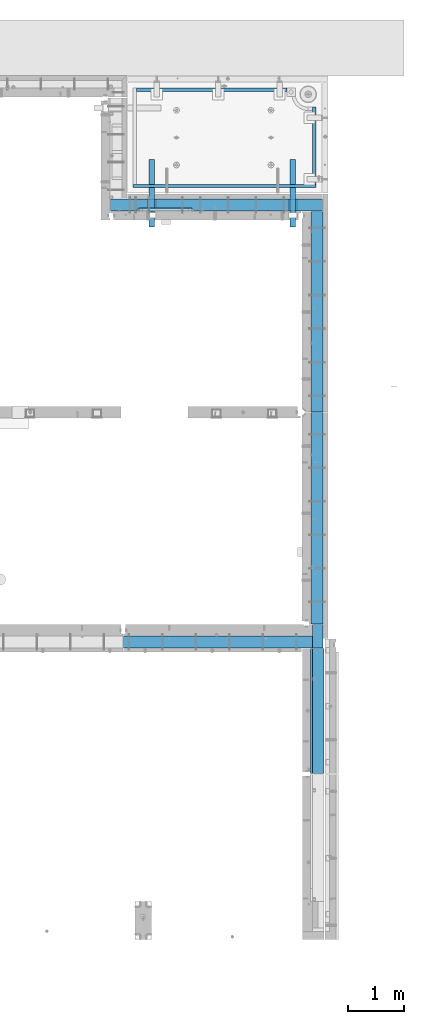
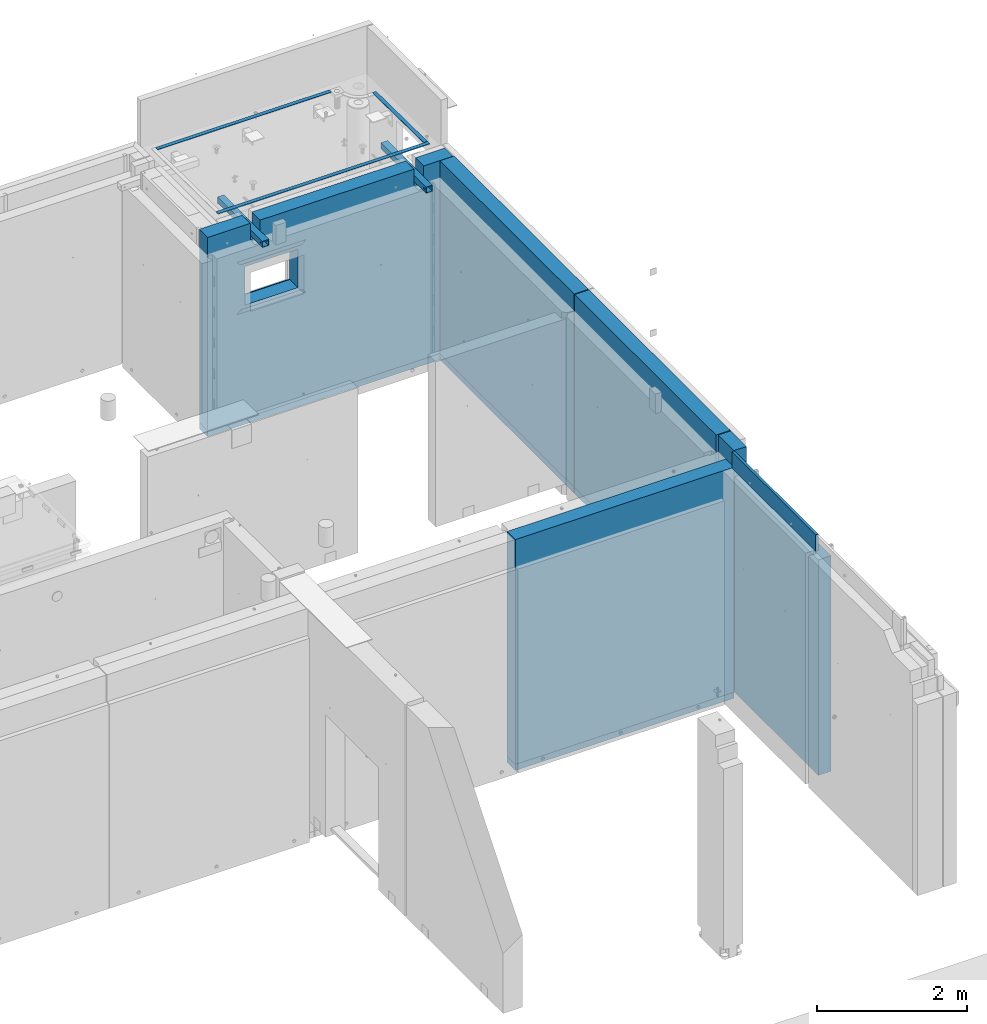
# One storey, part 83 of 264: 18 beams, 13 elements without a shape of their own.
"""IFC2X3 building model written with IfcOpenShell, lengths in millimetres."""

from ifc_helpers import new_model, si_unit, frame, origin_with_axes, place, context, subcontext, project, spatial, faceted_brep, material, type_object, element, aggregate, save


model = new_model("IFC2X3")

# Units and contexts
model_context = context("Model", 3, precision=1e-05, world=origin_with_axes())
body_context = subcontext(model_context, "Body", "Model", "MODEL_VIEW")
ifc_project = project(units=[si_unit("LENGTHUNIT", "METRE", prefix="MILLI"), si_unit("AREAUNIT", "SQUARE_METRE"), si_unit("VOLUMEUNIT", "CUBIC_METRE"), si_unit("MASSUNIT", "GRAM", prefix="KILO"), si_unit("TIMEUNIT", "SECOND"), si_unit("PLANEANGLEUNIT", "RADIAN"), si_unit("SOLIDANGLEUNIT", "STERADIAN"), si_unit("THERMODYNAMICTEMPERATUREUNIT", "DEGREE_CELSIUS"), si_unit("LUMINOUSINTENSITYUNIT", "LUMEN")], contexts=[model_context])

# Site, building, storey
site_placement = place(None, origin_with_axes())
site = spatial("IfcSite", under=ifc_project, at=site_placement, CompositionType="ELEMENT")
building_placement = place(site_placement, origin_with_axes())
building = spatial("IfcBuilding", under=site, at=building_placement, CompositionType="ELEMENT")
storey_placement = place(building_placement, origin_with_axes())
storey = spatial("IfcBuildingStorey", under=building, at=storey_placement, Name="K", CompositionType="ELEMENT", Elevation=0.0)

# Assemblies, beams
assembly_1_placement = place(storey_placement, origin_with_axes())
assembly_1 = element("IfcElementAssembly", 1, at=assembly_1_placement, inside=storey, AssemblyPlace="NOTDEFINED", PredefinedType="REINFORCEMENT_UNIT")
assembly_2_placement = place(assembly_1_placement, origin_with_axes())
assembly_2 = element("IfcElementAssembly", 2, at=assembly_2_placement, AssemblyPlace="NOTDEFINED", PredefinedType="NOTDEFINED")
ifc_material_1 = material(Name="Undefined/350")
beam_type_1 = type_object("IfcBeamType", Name="100X100X5", PredefinedType="NOTDEFINED")
beam_1_placement = place(assembly_2_placement, frame((34735.0001432011, 21500.0034426031, 81555.0), z_axis=(0.0, 0.0, 1.0), x_axis=(-2.2242999997242e-05, -0.999999999752625, 0.0)))
beam_1 = element("IfcBeam", 3, at=beam_1_placement, type_object=beam_type_1, material=ifc_material_1, ObjectType="100X100X5", context=body_context, shape_type="Brep", body=[
    faceted_brep([(1143.75108023171, 44.9999999999982, -10.8253175473074), (1143.75107855316, 50.0255964196231, -10.8253175473074), (1139.17576100585, 50.0255948914664, -6.25), (1139.1757626844, 44.9999999999982, -6.25), (1150.00108023171, 44.9999999999982, -12.5), (1150.00107855316, 50.0255985071226, -12.5), (1156.2510802317, 44.9999999999982, -10.8253175473074), (1156.25107855315, 50.0256005946221, -10.8253175473074), (1160.82639777901, 44.9999999999982, -6.25), (1160.82639610046, 50.0256021227788, -6.25), (1162.50108023171, 44.9999999999982, 0.0), (1162.50107855316, 50.0256026821226, 0.0), (1160.82639777901, 44.9999999999982, 6.25), (1160.82639610046, 50.0256021227788, 6.25), (1156.2510802317, 44.9999999999982, 10.8253175473074), (1156.25107855315, 50.0256005946221, 10.8253175473074), (1150.00108023171, 44.9999999999982, 12.5), (1150.00107855316, 50.0255985071226, 12.5), (1143.75108023171, 44.9999999999982, 10.8253175473074), (1143.75107855316, 50.0255964196231, 10.8253175473074), (1139.1757626844, 44.9999999999982, 6.25), (1139.17576100585, 50.0255948914664, 6.25), (1137.5010802317, 44.9999999999982, 0.0), (1137.50107855316, 50.0255943321226, 0.0), (1143.75111195316, -49.9744035792783, -10.8253175473074), (1143.75111029171, -44.9999999999991, -10.8253175473074), (1139.1757927444, -44.9999999999991, -6.25), (1139.17579440585, -49.9744051074349, -6.25), (1150.00111195316, -49.9744014917787, -12.5), (1150.00111029171, -44.9999999999991, -12.5), (1156.25111195316, -49.9743994042774, -10.8253175473074), (1156.25111029171, -44.9999999999991, -10.8253175473074), (1160.82642950046, -49.9743978761207, -6.25), (1160.82642783901, -44.9999999999991, -6.25), (1162.50111195316, -49.9743973167779, 0.0), (1162.50111029171, -44.9999999999991, 0.0), (1160.82642950046, -49.9743978761207, 6.25), (1160.82642783901, -44.9999999999991, 6.25), (1156.25111195316, -49.9743994042774, 10.8253175473074), (1156.25111029171, -44.9999999999991, 10.8253175473074), (1150.00111195316, -49.9744014917787, 12.5), (1150.00111029171, -44.9999999999991, 12.5), (1143.75111195316, -49.9744035792783, 10.8253175473074), (1143.75111029171, -44.9999999999991, 10.8253175473074), (1139.17579440585, -49.9744051074349, 6.25), (1139.1757927444, -44.9999999999991, 6.25), (1137.50111195316, -49.9744056667778, 0.0), (1137.50111029171, -44.9999999999991, 0.0), (1.81898940354586e-12, -50.0000000000009, -50.0), (1.81898940354586e-12, 49.9999999999991, -50.0), (1200.00449189278, 49.9999999999982, -50.0), (1200.00449189278, -50.0000000000009, -50.0), (1.81898940354586e-12, 49.9999999999991, 50.0), (1.81898940354586e-12, -50.0000000000009, 50.0), (1200.00449189278, -50.0000000000009, 50.0), (1200.00449189278, 49.9999999999982, 50.0), (0.0, 44.9999999999991, 45.0), (1.81898940354586e-12, -45.0000000000009, 45.0), (1.81898940354586e-12, -45.0000000000009, -45.0), (0.0, 44.9999999999991, -45.0), (1200.00449189278, 44.9999999999982, -45.0), (1200.00449189278, 44.9999999999982, 45.0), (1200.00449189278, -45.0000000000009, 45.0), (1200.00449189278, -45.0000000000009, -45.0)], [[[0, 1, 2, 3]], [[4, 5, 1, 0]], [[6, 7, 5, 4]], [[8, 9, 7, 6]], [[10, 11, 9, 8]], [[12, 13, 11, 10]], [[14, 15, 13, 12]], [[16, 17, 15, 14]], [[18, 19, 17, 16]], [[20, 21, 19, 18]], [[22, 23, 21, 20]], [[3, 2, 23, 22]], [[24, 25, 26, 27]], [[28, 29, 25, 24]], [[30, 31, 29, 28]], [[32, 33, 31, 30]], [[34, 35, 33, 32]], [[36, 37, 35, 34]], [[38, 39, 37, 36]], [[40, 41, 39, 38]], [[42, 43, 41, 40]], [[44, 45, 43, 42]], [[46, 47, 45, 44]], [[27, 26, 47, 46]], [[48, 49, 50, 51]], [[52, 53, 54, 55]], [[49, 52, 55, 50], [15, 17, 19, 21, 23, 2, 1, 5, 7, 9, 11, 13]], [[48, 53, 52, 49], [56, 57, 58, 59]], [[56, 59, 60, 61], [6, 4, 0, 3, 22, 20, 18, 16, 14, 12, 10, 8]], [[57, 56, 61, 62]], [[58, 57, 62, 63], [39, 41, 43, 45, 47, 26, 25, 29, 31, 33, 35, 37]], [[59, 58, 63, 60]], [[54, 51, 50, 55], [62, 61, 60, 63]], [[53, 48, 51, 54], [30, 28, 24, 27, 46, 44, 42, 40, 38, 36, 34, 32]]]),
])
aggregate(assembly_2, [beam_1])
assembly_3_placement = place(assembly_1_placement, origin_with_axes())
assembly_3 = element("IfcElementAssembly", 4, at=assembly_3_placement, AssemblyPlace="NOTDEFINED", PredefinedType="NOTDEFINED")
beam_2_placement = place(assembly_3_placement, frame((32210.0001432011, 21500.0034426031, 81555.0), z_axis=(0.0, 0.0, 1.0), x_axis=(-2.2242999997242e-05, -0.999999999752625, 0.0)))
beam_2 = element("IfcBeam", 5, at=beam_2_placement, type_object=beam_type_1, material=ifc_material_1, ObjectType="100X100X5", context=body_context, shape_type="Brep", body=[
    faceted_brep([(1143.75108023171, 44.9999999999982, -10.8253175473074), (1143.75107855316, 50.0255964196231, -10.8253175473074), (1139.17576100585, 50.0255948914664, -6.25), (1139.1757626844, 44.9999999999982, -6.25), (1150.00108023171, 44.9999999999982, -12.5), (1150.00107855316, 50.0255985071226, -12.5), (1156.2510802317, 44.9999999999982, -10.8253175473074), (1156.25107855315, 50.0256005946221, -10.8253175473074), (1160.82639777901, 44.9999999999982, -6.25), (1160.82639610046, 50.0256021227788, -6.25), (1162.50108023171, 44.9999999999982, 0.0), (1162.50107855316, 50.0256026821226, 0.0), (1160.82639777901, 44.9999999999982, 6.25), (1160.82639610046, 50.0256021227788, 6.25), (1156.2510802317, 44.9999999999982, 10.8253175473074), (1156.25107855315, 50.0256005946221, 10.8253175473074), (1150.00108023171, 44.9999999999982, 12.5), (1150.00107855316, 50.0255985071226, 12.5), (1143.75108023171, 44.9999999999982, 10.8253175473074), (1143.75107855316, 50.0255964196231, 10.8253175473074), (1139.1757626844, 44.9999999999982, 6.25), (1139.17576100585, 50.0255948914664, 6.25), (1137.5010802317, 44.9999999999982, 0.0), (1137.50107855316, 50.0255943321226, 0.0), (1143.75111195316, -49.9744035792783, -10.8253175473074), (1143.75111029171, -44.9999999999991, -10.8253175473074), (1139.1757927444, -44.9999999999991, -6.25), (1139.17579440585, -49.9744051074349, -6.25), (1150.00111195316, -49.9744014917787, -12.5), (1150.00111029171, -44.9999999999991, -12.5), (1156.25111195316, -49.9743994042774, -10.8253175473074), (1156.25111029171, -44.9999999999991, -10.8253175473074), (1160.82642950046, -49.9743978761207, -6.25), (1160.82642783901, -44.9999999999991, -6.25), (1162.50111195316, -49.9743973167779, 0.0), (1162.50111029171, -44.9999999999991, 0.0), (1160.82642950046, -49.9743978761207, 6.25), (1160.82642783901, -44.9999999999991, 6.25), (1156.25111195316, -49.9743994042774, 10.8253175473074), (1156.25111029171, -44.9999999999991, 10.8253175473074), (1150.00111195316, -49.9744014917787, 12.5), (1150.00111029171, -44.9999999999991, 12.5), (1143.75111195316, -49.9744035792783, 10.8253175473074), (1143.75111029171, -44.9999999999991, 10.8253175473074), (1139.17579440585, -49.9744051074349, 6.25), (1139.1757927444, -44.9999999999991, 6.25), (1137.50111195316, -49.9744056667778, 0.0), (1137.50111029171, -44.9999999999991, 0.0), (1.81898940354586e-12, -50.0000000000009, -50.0), (1.81898940354586e-12, 49.9999999999991, -50.0), (1200.00449189278, 49.9999999999982, -50.0), (1200.00449189278, -50.0000000000009, -50.0), (1.81898940354586e-12, 49.9999999999991, 50.0), (1.81898940354586e-12, -50.0000000000009, 50.0), (1200.00449189278, -50.0000000000009, 50.0), (1200.00449189278, 49.9999999999982, 50.0), (0.0, 44.9999999999991, 45.0), (1.81898940354586e-12, -45.0000000000009, 45.0), (1.81898940354586e-12, -45.0000000000009, -45.0), (0.0, 44.9999999999991, -45.0), (1200.00449189278, 44.9999999999982, -45.0), (1200.00449189278, 44.9999999999982, 45.0), (1200.00449189278, -45.0000000000009, 45.0), (1200.00449189278, -45.0000000000009, -45.0)], [[[0, 1, 2, 3]], [[4, 5, 1, 0]], [[6, 7, 5, 4]], [[8, 9, 7, 6]], [[10, 11, 9, 8]], [[12, 13, 11, 10]], [[14, 15, 13, 12]], [[16, 17, 15, 14]], [[18, 19, 17, 16]], [[20, 21, 19, 18]], [[22, 23, 21, 20]], [[3, 2, 23, 22]], [[24, 25, 26, 27]], [[28, 29, 25, 24]], [[30, 31, 29, 28]], [[32, 33, 31, 30]], [[34, 35, 33, 32]], [[36, 37, 35, 34]], [[38, 39, 37, 36]], [[40, 41, 39, 38]], [[42, 43, 41, 40]], [[44, 45, 43, 42]], [[46, 47, 45, 44]], [[27, 26, 47, 46]], [[48, 49, 50, 51]], [[52, 53, 54, 55]], [[49, 52, 55, 50], [15, 17, 19, 21, 23, 2, 1, 5, 7, 9, 11, 13]], [[48, 53, 52, 49], [56, 57, 58, 59]], [[56, 59, 60, 61], [6, 4, 0, 3, 22, 20, 18, 16, 14, 12, 10, 8]], [[57, 56, 61, 62]], [[58, 57, 62, 63], [39, 41, 43, 45, 47, 26, 25, 29, 31, 33, 35, 37]], [[59, 58, 63, 60]], [[54, 51, 50, 55], [62, 61, 60, 63]], [[53, 48, 51, 54], [30, 28, 24, 27, 46, 44, 42, 40, 38, 36, 34, 32]]]),
])
aggregate(assembly_3, [beam_2])
ifc_material_2 = material(Name="CONCRETE/Concrete_Undefined")
beam_type_2 = type_object("IfcBeamType", PredefinedType="NOTDEFINED")
beam_3_placement = place(assembly_1_placement, frame((31939.9962088559, 22755.0460044387, 81704.8214945609), z_axis=(-6.06120000110142e-05, 1.00000033869885e-09, 0.999999998163093), x_axis=(0.999999998046552, -1.52670000006885e-05, 6.06120000021532e-05)))
beam_3 = element("IfcBeam", 6, at=beam_3_placement, type_object=beam_type_2, material=ifc_material_2, context=body_context, shape_type="Brep", body=[
    faceted_brep([(2.5465851649642e-11, 29.9999999999982, -4.99999999998545), (-2.91038304567337e-11, 29.9999999999982, 5.0), (2689.99575395095, 29.9999999999964, 5.0), (2689.99575395095, 30.0000000000036, -4.99999999998545), (-2.5465851649642e-11, -30.0000000000018, 5.0), (2689.99575395095, -30.0000000000036, 5.00000000001455), (2.72848410531878e-11, -30.0000000000018, -4.99999999998545), (2689.99575395095, -29.9999999999964, -4.99999999998545)], [[[0, 1, 2, 3]], [[1, 4, 5, 2]], [[4, 6, 7, 5]], [[6, 0, 3, 7]], [[5, 7, 3, 2]], [[6, 4, 1, 0]]]),
])
beam_4_placement = place(assembly_1_placement, frame((35120.0586113047, 21059.9283388168, 81725.6638339053), z_axis=(-5.46000002942176e-07, 0.0130421150000144, 0.999914948001093), x_axis=(-4.18520000064741e-05, 0.999914947125351, -0.0130421150016393)))
beam_4 = element("IfcBeam", 7, at=beam_4_placement, type_object=beam_type_2, material=ifc_material_2, context=body_context, shape_type="Brep", body=[
    faceted_brep([(2.5465851649642e-11, 29.9999999999982, -4.99999999998545), (-2.91038304567337e-11, 29.9999999999982, 5.0), (1380.14316164461, 30.0, 5.00000000001455), (1380.1431616447, 29.9999999999927, -5.0), (-2.5465851649642e-11, -30.0000000000018, 5.0), (1380.14316164461, -30.0, 5.00000000001455), (2.72848410531878e-11, -30.0000000000018, -4.99999999998545), (1380.1431616447, -30.0, -5.0)], [[[0, 1, 2, 3]], [[1, 4, 5, 2]], [[4, 6, 7, 5]], [[6, 0, 3, 7]], [[5, 7, 3, 2]], [[6, 4, 1, 0]]]),
])
beam_5_placement = place(assembly_1_placement, frame((31879.9986204165, 21030.068155681, 81725.2788443041), z_axis=(-0.000117617000009658, 3.00000101585662e-09, 0.999999993083121), x_axis=(0.999999992839137, -2.20899999960382e-05, 0.000117616999982089)))
beam_5 = element("IfcBeam", 8, at=beam_5_placement, type_object=beam_type_2, material=ifc_material_2, context=body_context, shape_type="Brep", body=[
    faceted_brep([(2.5465851649642e-11, 29.9999999999982, -4.99999999998545), (-2.91038304567337e-11, 29.9999999999982, 5.0), (3270.06002088557, 30.0, 5.0), (3270.06002088557, 30.0000000000036, -5.0), (-2.5465851649642e-11, -30.0000000000018, 5.0), (3270.06002088557, -30.0, 5.0), (2.72848410531878e-11, -30.0000000000018, -4.99999999998545), (3270.06002088558, -29.9999999999964, -5.0)], [[[0, 1, 2, 3]], [[1, 4, 5, 2]], [[4, 6, 7, 5]], [[6, 0, 3, 7]], [[5, 7, 3, 2]], [[6, 4, 1, 0]]]),
])
aggregate(assembly_1, [assembly_2, assembly_3, beam_3, beam_4, beam_5])

# Assembly, beams
assembly_4_placement = place(storey_placement, origin_with_axes())
assembly_4 = element("IfcElementAssembly", 9, at=assembly_4_placement, inside=storey, AssemblyPlace="NOTDEFINED", PredefinedType="REINFORCEMENT_UNIT")
ifc_material_3 = material(Name="CONCRETE/C25/30")
beam_type_3 = type_object("IfcBeamType", PredefinedType="NOTDEFINED")
beam_6_placement = place(assembly_4_placement, frame((32995.0013718009, 20610.0, 81145.0), z_axis=(0.0, 0.0, -1.0), x_axis=(-1.0, 3.00000001838171e-08, 0.0)))
beam_6 = element("IfcBeam", 10, at=beam_6_placement, type_object=beam_type_3, material=ifc_material_3, context=body_context, shape_type="Brep", body=[
    faceted_brep([(60.0000000000073, 30.0, 30.0), (0.0, -30.0, -30.0), (60.0000000000073, -30.0, 30.0), (1010.00305175781, 30.0, 30.0), (1070.00305175781, -30.0, -30.0), (1010.00305175781, -30.0, 30.0)], [[[0, 1, 2]], [[1, 0, 3, 4]], [[2, 1, 4, 5]], [[0, 2, 5, 3]], [[4, 3, 5]]]),
])
beam_7_placement = place(assembly_4_placement, frame((31924.9983200431, 20610.0, 80350.0), z_axis=(0.0, 0.0, 1.0), x_axis=(1.0, 0.0, 0.0)))
beam_7 = element("IfcBeam", 11, at=beam_7_placement, type_object=beam_type_3, material=ifc_material_3, context=body_context, shape_type="Brep", body=[
    faceted_brep([(1070.00305175781, -30.0, -30.0), (1010.00305175781, 30.0, 30.0), (1010.00305175781, -30.0, 30.0), (60.0000000000073, 30.0, 30.0), (60.0000000000073, -30.0, 30.0), (0.0, -30.0, -30.0)], [[[0, 1, 2]], [[3, 4, 2, 1]], [[3, 5, 4]], [[4, 5, 0, 2]], [[5, 3, 1, 0]]]),
])

# Assembly, beam
assembly_5_placement = place(storey_placement, origin_with_axes())
assembly_5 = element("IfcElementAssembly", 12, at=assembly_5_placement, inside=storey, AssemblyPlace="NOTDEFINED", PredefinedType="REINFORCEMENT_UNIT")
beam_type_4 = type_object("IfcBeamType", PredefinedType="NOTDEFINED")
beam_8_placement = place(assembly_5_placement, frame((35085.0024573137, 12870.0018965848, 77750.0), z_axis=(0.0, 0.0, 1.0), x_axis=(-1.0, 3.00000001838171e-08, 0.0)))
beam_8 = element("IfcBeam", 13, at=beam_8_placement, type_object=beam_type_4, material=ifc_material_3, context=body_context, shape_type="Brep", body=[
    faceted_brep([(-3.63797880709171e-12, 109.999999999996, -50.0), (-3.63797880709171e-12, 109.999999999996, 50.0), (3375.0, 110.0, 50.0), (3375.0, 110.0, -50.0), (-3.63797880709171e-12, -110.0, 50.0), (3375.0, -110.0, 50.0), (-3.63797880709171e-12, -110.0, -50.0), (3375.0, -110.0, -50.0)], [[[0, 1, 2, 3]], [[1, 4, 5, 2]], [[4, 6, 7, 5]], [[6, 0, 3, 7]], [[5, 7, 3, 2]], [[6, 4, 1, 0]]]),
])

assembly_6_placement = place(storey_placement, origin_with_axes())
assembly_6 = element("IfcElementAssembly", 14, at=assembly_6_placement, inside=storey, AssemblyPlace="NOTDEFINED", PredefinedType="REINFORCEMENT_UNIT")
beam_9_placement = place(assembly_6_placement, frame((35170.0000031915, 16975.0004177926, 78540.0), z_axis=(0.0, 0.0, 1.0), x_axis=(0.0, -1.0, 0.0)))
beam_9 = element("IfcBeam", 15, at=beam_9_placement, type_object=beam_type_4, material=ifc_material_3, context=body_context, shape_type="Brep", body=[
    faceted_brep([(0.000245261930103879, 110.000000000007, -50.0), (0.000245261930103879, 110.000000000007, 50.0), (3779.99844964643, 110.000000000007, 50.0), (3779.99844964643, 110.000000000007, -50.0), (0.00010204192949459, -110.0, 50.0), (3779.99844964643, -110.0, 50.0), (0.00010204192949459, -110.0, -50.0), (3779.99844964643, -110.0, -50.0)], [[[0, 1, 2, 3]], [[1, 4, 5, 2]], [[4, 6, 7, 5]], [[6, 0, 3, 7]], [[5, 7, 3, 2]], [[6, 4, 1, 0]]]),
])

assembly_7_placement = place(storey_placement, origin_with_axes())
assembly_7 = element("IfcElementAssembly", 16, at=assembly_7_placement, inside=storey, AssemblyPlace="NOTDEFINED", PredefinedType="REINFORCEMENT_UNIT")
beam_10_placement = place(assembly_7_placement, frame((35170.0, 20575.0, 78540.0), z_axis=(0.0, 0.0, 1.0), x_axis=(0.0, -1.0, 0.0)))
beam_10 = element("IfcBeam", 17, at=beam_10_placement, type_object=beam_type_4, material=ifc_material_3, context=body_context, shape_type="Brep", body=[
    faceted_brep([(-3.63797880709171e-12, 109.999999999996, -50.0), (-3.63797880709171e-12, 109.999999999996, 50.0), (3584.99975585938, 110.0, 50.0), (3584.99975585938, 110.0, -50.0), (-3.63797880709171e-12, -110.0, 50.0), (3584.99975585938, -110.0, 50.0), (-3.63797880709171e-12, -110.0, -50.0), (3584.99975585938, -110.0, -50.0)], [[[0, 1, 2, 3]], [[1, 4, 5, 2]], [[4, 6, 7, 5]], [[6, 0, 3, 7]], [[5, 7, 3, 2]], [[6, 4, 1, 0]]]),
])

# Beam
ifc_material_4 = material(Name="CONCRETE/C30/37")
beam_11_placement = place(assembly_4_placement, frame((31474.9952566975, 20690.0, 78540.0), z_axis=(0.0, 0.0, 1.0), x_axis=(1.0, 0.0, 0.0)))
beam_11 = element("IfcBeam", 18, at=beam_11_placement, type_object=beam_type_4, material=ifc_material_4, context=body_context, shape_type="Brep", body=[
    faceted_brep([(-3.63797880709171e-12, 109.999999999996, -50.0), (-3.63797880709171e-12, 109.999999999996, 50.0), (3790.00474330254, 110.0, 50.0), (3790.00474330254, 110.0, -50.0), (-3.63797880709171e-12, -110.0, 50.0), (3790.00474330254, -110.0, 50.0), (-3.63797880709171e-12, -110.0, -50.0), (3790.00474330254, -110.0, -50.0)], [[[0, 1, 2, 3]], [[1, 4, 5, 2]], [[4, 6, 7, 5]], [[6, 0, 3, 7]], [[5, 7, 3, 2]], [[6, 4, 1, 0]]]),
])

ifc_material_5 = material(Name="EPS100")
beam_type_5 = type_object("IfcBeamType", PredefinedType="NOTDEFINED")
beam_12_placement = place(assembly_5_placement, frame((35180.0024573138, 13180.0018965848, 79770.0), z_axis=(0.0, 0.0, 1.0), x_axis=(0.0, -1.0, 0.0)))
beam_12 = element("IfcBeam", 19, at=beam_12_placement, type_object=beam_type_5, material=ifc_material_5, context=body_context, shape_type="Brep", body=[
    faceted_brep([(0.0, 95.0, -1970.0), (0.0, 95.0, 1970.0), (420.0, 95.0, 1970.0), (420.0, 95.0, -1970.0), (0.0, -95.0, 1970.0), (420.0, -95.0, 1970.0), (0.0, -95.0, -1970.0), (420.0, -95.0, -1970.0)], [[[0, 1, 2, 3]], [[1, 4, 5, 2]], [[4, 6, 7, 5]], [[6, 0, 3, 7]], [[5, 7, 3, 2]], [[6, 4, 1, 0]]]),
])

# Assemblies, beams
assembly_8_placement = place(storey_placement, origin_with_axes())
assembly_8 = element("IfcElementAssembly", 20, at=assembly_8_placement, inside=storey, AssemblyPlace="NOTDEFINED", PredefinedType="REINFORCEMENT_UNIT")
beam_type_6 = type_object("IfcBeamType", Name="270X40", PredefinedType="NOTDEFINED")
beam_13_placement = place(assembly_8_placement, frame((35070.0024573138, 12755.0018965848, 81605.0), z_axis=(0.0, 0.0, 1.0), x_axis=(0.0, -1.0, 0.0)))
beam_13 = element("IfcBeam", 21, at=beam_13_placement, type_object=beam_type_6, material=ifc_material_4, ObjectType="270X40", context=body_context, shape_type="Brep", body=[
    faceted_brep([(0.0, 20.0, -135.0), (0.0, 20.0, 135.0), (2240.00000000001, 20.0, 135.0), (2240.00000000001, 20.0, -135.0), (0.0, -20.0, 135.0), (2240.00000000001, -20.0, 135.0), (0.0, -20.0, -135.0), (2240.00000000001, -20.0, -135.0)], [[[0, 1, 2, 3]], [[1, 4, 5, 2]], [[4, 6, 7, 5]], [[6, 0, 3, 7]], [[5, 7, 3, 2]], [[6, 4, 1, 0]]]),
])
assembly_9_placement = place(assembly_8_placement, origin_with_axes())
assembly_9 = element("IfcElementAssembly", 22, at=assembly_9_placement, Name="Steel Assembly", AssemblyPlace="NOTDEFINED", PredefinedType="NOTDEFINED")
aggregate(assembly_8, [beam_13, assembly_9])
beam_type_7 = type_object("IfcBeamType", PredefinedType="NOTDEFINED")
beam_14_placement = place(assembly_9_placement, frame((35190.0024573137, 12755.0018965848, 79557.5), z_axis=(0.0, 0.0, 1.0), x_axis=(0.0, -1.0, 0.0)))
beam_14 = element("IfcBeam", 23, at=beam_14_placement, type_object=beam_type_7, material=ifc_material_5, context=body_context, shape_type="Brep", body=[
    faceted_brep([(0.0, 100.0, -1757.5), (0.0, 100.0, 1757.5), (2240.0, 100.0, 1757.5), (2240.0, 100.0, -1757.5), (0.0, -100.0, 1757.5), (2240.0, -100.0, 1757.5), (0.0, -100.0, -1757.5), (2240.0, -100.0, -1757.5)], [[[0, 1, 2, 3]], [[1, 4, 5, 2]], [[4, 6, 7, 5]], [[6, 0, 3, 7]], [[5, 7, 3, 2]], [[6, 4, 1, 0]]]),
])
aggregate(assembly_9, [beam_14])

# Assembly
assembly_10_placement = place(assembly_5_placement, origin_with_axes())
assembly_10 = element("IfcElementAssembly", 24, at=assembly_10_placement, Name="Steel Assembly", AssemblyPlace="NOTDEFINED", PredefinedType="NOTDEFINED")

aggregate(assembly_5, [beam_12, beam_8, assembly_10])

# Beam
beam_type_8 = type_object("IfcBeamType", PredefinedType="NOTDEFINED")
beam_15_placement = place(assembly_10_placement, frame((35085.0024573137, 12870.0018965848, 79635.0), z_axis=(0.0, 0.0, 1.0), x_axis=(-1.0, 3.00000001838171e-08, 0.0)))
beam_15 = element("IfcBeam", 25, at=beam_15_placement, type_object=beam_type_8, material=ifc_material_5, context=body_context, shape_type="Brep", body=[
    faceted_brep([(0.0, 110.0, -1835.0), (0.0, 110.0, 1835.0), (3375.0, 110.0, 1835.0), (3375.0, 110.0, -1835.0), (0.0, -110.0, 1835.0), (3375.0, -110.0, 1835.0), (0.0, -110.0, -1835.0), (3375.0, -110.0, -1835.0)], [[[0, 1, 2, 3]], [[1, 4, 5, 2]], [[4, 6, 7, 5]], [[6, 0, 3, 7]], [[5, 7, 3, 2]], [[6, 4, 1, 0]]]),
])

aggregate(assembly_10, [beam_15])

# Assembly
assembly_11_placement = place(assembly_6_placement, origin_with_axes())
assembly_11 = element("IfcElementAssembly", 26, at=assembly_11_placement, Name="Steel Assembly", AssemblyPlace="NOTDEFINED", PredefinedType="NOTDEFINED")

aggregate(assembly_6, [beam_9, assembly_11])

# Beam
beam_type_9 = type_object("IfcBeamType", PredefinedType="NOTDEFINED")
beam_16_placement = place(assembly_11_placement, frame((35170.0000031915, 16975.0004177913, 80165.0), z_axis=(0.0, 0.0, 1.0), x_axis=(0.0, -1.0, 0.0)))
beam_16 = element("IfcBeam", 27, at=beam_16_placement, type_object=beam_type_9, material=ifc_material_5, context=body_context, shape_type="Brep", body=[
    faceted_brep([(-7.27595761418343e-12, 110.000000000007, -1575.0), (-7.27595761418343e-12, 110.000000000007, 1575.0), (3779.99844965522, 110.000000000007, 1575.0), (3779.99844965522, 110.000000000007, -1575.0), (-7.27595761418343e-12, -110.0, 1575.0), (3779.99844965523, -110.0, 1575.0), (-7.27595761418343e-12, -110.0, -1575.0), (3779.99844965523, -110.0, -1575.0)], [[[0, 1, 2, 3]], [[1, 4, 5, 2]], [[4, 6, 7, 5]], [[6, 0, 3, 7]], [[5, 7, 3, 2]], [[6, 4, 1, 0]]]),
])

aggregate(assembly_11, [beam_16])

# Assembly
assembly_12_placement = place(assembly_7_placement, origin_with_axes())
assembly_12 = element("IfcElementAssembly", 28, at=assembly_12_placement, Name="Steel Assembly", AssemblyPlace="NOTDEFINED", PredefinedType="NOTDEFINED")

aggregate(assembly_7, [beam_10, assembly_12])

# Beam
beam_17_placement = place(assembly_12_placement, frame((35170.0, 20575.0, 80165.0), z_axis=(0.0, 0.0, 1.0), x_axis=(0.0, -1.0, 0.0)))
beam_17 = element("IfcBeam", 29, at=beam_17_placement, type_object=beam_type_9, material=ifc_material_5, context=body_context, shape_type="Brep", body=[
    faceted_brep([(-7.27595761418343e-12, 110.000000000007, -1575.0), (-7.27595761418343e-12, 110.000000000007, 1575.0), (3584.99975585938, 110.0, 1575.0), (3584.99975585938, 110.0, -1575.0), (-7.27595761418343e-12, -110.0, 1575.0), (3584.99975585938, -110.0, 1575.0), (-7.27595761418343e-12, -110.0, -1575.0), (3584.99975585938, -110.0, -1575.0)], [[[0, 1, 2, 3]], [[1, 4, 5, 2]], [[4, 6, 7, 5]], [[6, 0, 3, 7]], [[5, 7, 3, 2]], [[6, 4, 1, 0]]]),
])

aggregate(assembly_12, [beam_17])

# Assembly
assembly_13_placement = place(assembly_4_placement, origin_with_axes())
assembly_13 = element("IfcElementAssembly", 30, at=assembly_13_placement, Name="Steel Assembly", AssemblyPlace="NOTDEFINED", PredefinedType="NOTDEFINED")

aggregate(assembly_4, [beam_6, beam_7, beam_11, assembly_13])

# Beam
beam_18_placement = place(assembly_13_placement, frame((31474.9952566975, 20690.0, 80165.0), z_axis=(0.0, 0.0, 1.0), x_axis=(1.0, 0.0, 0.0)))
beam_18 = element("IfcBeam", 31, at=beam_18_placement, type_object=beam_type_9, material=ifc_material_5, context=body_context, shape_type="Brep", body=[
    faceted_brep([(3184.97819479133, 110.0, 1575.0), (3184.97819479133, -110.0, 1575.0), (3184.97819479133, -109.999999999996, 1305.0), (3184.97819479133, 110.0, 1305.0), (3334.97819479133, -109.999999999996, 1305.0), (3334.97819479133, 110.0, 1305.0), (3334.97819479133, 110.0, 1575.0), (3334.97819479133, -110.0, 1575.0), (809.978194791329, 110.0, 1575.0), (809.978194791329, -110.0, 1575.0), (809.978194791329, 110.0, 1305.0), (809.978194791329, -110.0, 1305.0), (659.978194791329, 110.0, 1305.0), (659.978194791329, -110.0, 1305.0), (659.978194791329, 110.0, 1575.0), (659.978194791329, -110.0, 1575.0), (-7.27595761418343e-12, 110.000000000007, 1575.0), (-7.27595761418343e-12, -110.0, 1575.0), (-7.27595761418343e-12, -110.0, -1575.0), (-7.27595761418343e-12, 110.000000000007, -1575.0), (3790.00474330254, 110.0, -1575.0), (3790.00474330254, -110.0, -1575.0), (3790.00474330254, -110.0, 1575.0), (3790.00474330254, 110.0, 1575.0), (574.327387669946, -110.0, 269.32432432432), (574.327387669946, -110.0, 895.67567567568), (1395.6787390213, -110.0, 895.67567567568), (1395.6787390213, -110.0, 269.32432432432), (1390.00306334562, 100.0, 275.0), (580.003063345623, 100.0, 275.0), (1390.00306334562, 100.0, 280.0), (580.003063345623, 100.0, 280.0), (580.003063345623, 100.0, 890.0), (1390.00306334562, 100.0, 890.0), (1390.00306334562, 110.0, 280.0), (1390.00306334562, 110.0, 890.0), (1360.00306334562, 110.0, 280.0), (610.003063345623, 110.0, 280.0), (580.003063345623, 110.0, 280.0), (580.003063345623, 110.0, 890.0)], [[[0, 1, 2, 3]], [[3, 2, 4, 5]], [[6, 5, 4, 7]], [[8, 9, 1, 0]], [[8, 10, 11, 9]], [[12, 13, 11, 10]], [[14, 15, 13, 12]], [[16, 17, 15, 14]], [[18, 17, 16, 19]], [[18, 19, 20, 21]], [[22, 21, 20, 23]], [[22, 23, 6, 7]], [[2, 1, 9, 11, 13, 15, 17, 18, 21, 22, 7, 4], [24, 25, 26, 27]], [[27, 28, 29, 24]], [[29, 28, 30, 31]], [[25, 24, 29, 31, 32]], [[26, 25, 32, 33]], [[28, 27, 26, 33, 30]], [[34, 30, 33, 35]], [[36, 37, 38, 31, 30, 34]], [[39, 32, 31, 38]], [[35, 33, 32, 39]], [[23, 20, 19, 16, 14, 12, 10, 8, 0, 3, 5, 6], [38, 37, 36, 34, 35, 39]]]),
])

aggregate(assembly_13, [beam_18])

save(model, "model.ifc")
